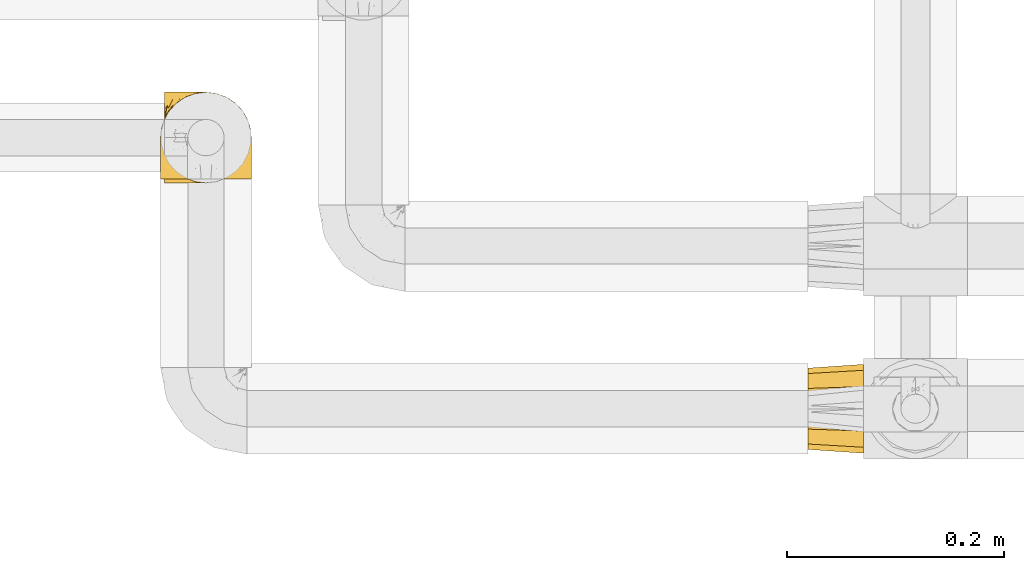
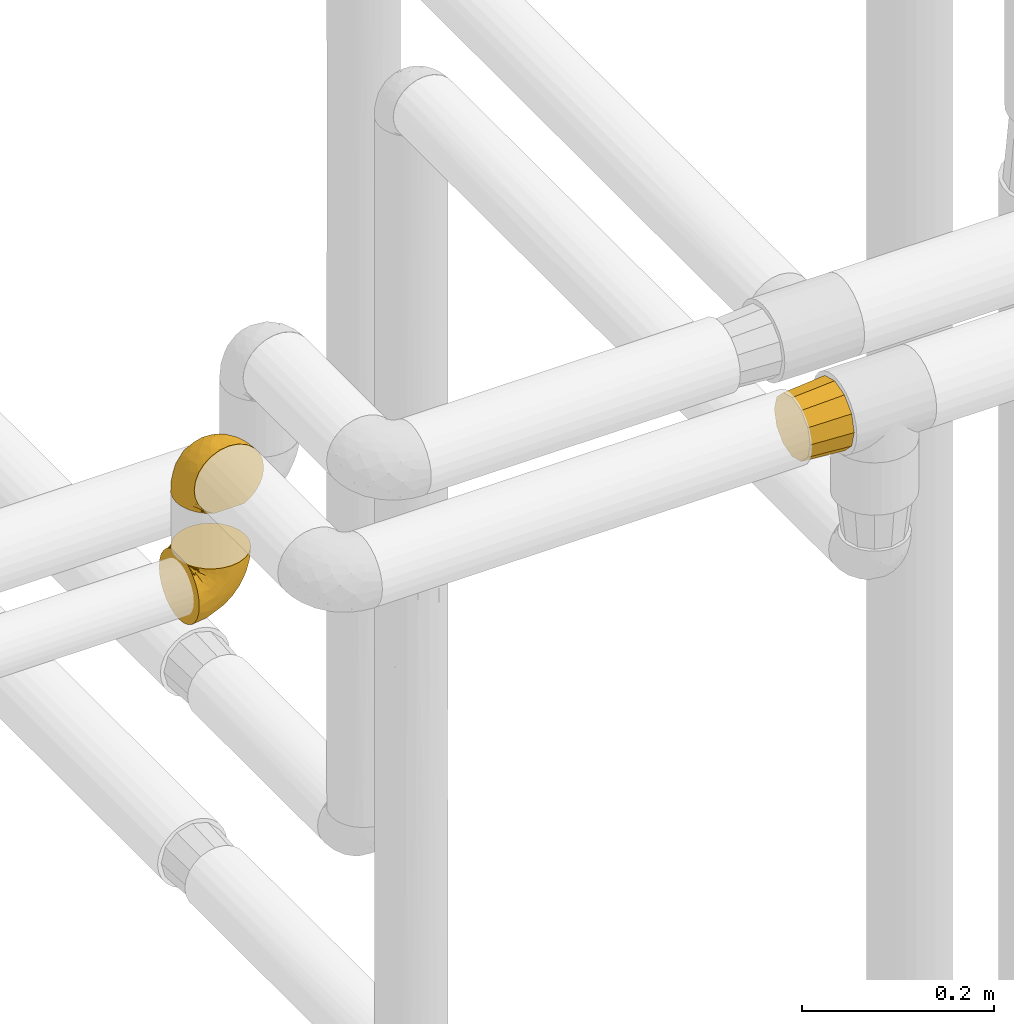
# One storey, part 58 of 827: 3 coverings.
"""IFC2X3 building model written with IfcOpenShell, lengths in millimetres."""

import ifcopenshell
import ifcopenshell.guid

model = None  # the IFC model being written
_history = None  # IfcOwnerHistory: only IFC2X3 demands one
_inside = {}  # id of a spatial element -> (the spatial element, [elements in it])
_under = {}  # id of a project, library or spatial element -> (it, [spatial elements below it])
_declared = {}  # id of a project -> (the project, [libraries it declares])
_typed = {}  # id of a type object -> (the type object, [elements of that type])
_made_of = {}  # id of a material, layer set ... -> (it, [elements and type objects made of it])


def new_model(schema):
    """Start an empty IFC model of exactly this schema.

    Asked for "IFC4X3", IfcOpenShell would pick the latest addendum, in which some entities
    have other attributes; the version numbers below select the first issue.
    IFC2X3 requires an IfcOwnerHistory on every rooted entity: one is made here for all.
    """
    global model, _history
    if schema == "IFC4X3":
        model = ifcopenshell.file(schema_version=(4, 3, 0, 0))
    else:
        model = ifcopenshell.file(schema=schema)
    _inside.clear()
    _under.clear()
    _declared.clear()
    _typed.clear()
    _made_of.clear()
    _history = None
    if model.schema == "IFC2X3":
        org = make("IfcOrganization", Name="unknown")
        user = make(
            "IfcPersonAndOrganization",
            ThePerson=make("IfcPerson", FamilyName="unknown"),
            TheOrganization=org,
        )
        app = make(
            "IfcApplication",
            ApplicationDeveloper=org,
            Version="unknown",
            ApplicationFullName="unknown",
            ApplicationIdentifier="unknown",
        )
        _history = make(
            "IfcOwnerHistory",
            OwningUser=user,
            OwningApplication=app,
            ChangeAction="ADDED",
            CreationDate=0,
        )
    return model


def make(cls, **values):
    """One entity of the class cls with the attributes given. An attribute that is None is left unset."""
    return model.create_entity(
        cls, **{name: value for name, value in values.items() if value is not None}
    )


def entity(cls, *values):
    """Any entity or typed value of the class cls, its attributes in the order of the schema. None: left unset."""
    e = model.create_entity(cls)
    for i, value in enumerate(values):
        if value is not None:
            e[i] = value
    return e


def rooted(cls, **values):
    """An entity with a GlobalId (a new one), such as an element, a storey or a relation."""
    return make(cls, GlobalId=ifcopenshell.guid.new(), OwnerHistory=_history, **values)


def si_unit(unit_type, name, prefix=None):
    """IfcSIUnit, for example si_unit("LENGTHUNIT", "METRE", prefix="MILLI")."""
    return make("IfcSIUnit", UnitType=unit_type, Prefix=prefix, Name=name)


def converted_unit(unit_type, name, factor, base, dimensions=None, offset=None):
    """IfcConversionBasedUnit, such as the inch: factor (a typed value) times the base unit."""
    return make(
        "IfcConversionBasedUnit"
        if offset is None
        else "IfcConversionBasedUnitWithOffset",
        ConversionOffset=offset,
        Dimensions=None
        if dimensions is None
        else entity("IfcDimensionalExponents", *dimensions),
        UnitType=unit_type,
        Name=name,
        ConversionFactor=make(
            "IfcMeasureWithUnit", ValueComponent=factor, UnitComponent=base
        ),
    )


def derived_unit(unit_type, elements):
    """IfcDerivedUnit: a product of units, each with its exponent."""
    return make(
        "IfcDerivedUnit",
        Elements=[
            make("IfcDerivedUnitElement", Unit=unit, Exponent=power)
            for unit, power in elements
        ],
        UnitType=unit_type,
    )


def assignment(units):
    """IfcUnitAssignment: the units of a project."""
    return None if units is None else make("IfcUnitAssignment", Units=units)


def point(xyz):
    """IfcCartesianPoint."""
    return None if xyz is None else make("IfcCartesianPoint", Coordinates=xyz)


def direction(xyz):
    """IfcDirection."""
    return None if xyz is None else make("IfcDirection", DirectionRatios=xyz)


def frame(location, z_axis=None, x_axis=None):
    """IfcAxis2Placement3D, a coordinate frame: its origin and axes. An axis left out is left unset."""
    return make(
        "IfcAxis2Placement3D",
        Location=point(location),
        Axis=direction(z_axis),
        RefDirection=direction(x_axis),
    )


def origin():
    """The frame at (0, 0, 0) with its axes left unset."""
    return frame((0.0, 0.0, 0.0))


def place(relative_to, where):
    """IfcLocalPlacement: puts the frame where relative to a parent placement (None: the world)."""
    return make(
        "IfcLocalPlacement", PlacementRelTo=relative_to, RelativePlacement=where
    )


def context(
    kind, dimensions, precision=None, world=None, true_north=None, identifier=None
):
    """IfcGeometricRepresentationContext, for example the 3D "Model" context."""
    return make(
        "IfcGeometricRepresentationContext",
        ContextIdentifier=identifier,
        ContextType=kind,
        CoordinateSpaceDimension=dimensions,
        Precision=precision,
        WorldCoordinateSystem=world,
        TrueNorth=true_north,
    )


def subcontext(parent, identifier, kind, view, scale=None):
    """IfcGeometricRepresentationSubContext, for example "Body" below "Model"."""
    return make(
        "IfcGeometricRepresentationSubContext",
        ContextIdentifier=identifier,
        ContextType=kind,
        ParentContext=parent,
        TargetScale=scale,
        TargetView=view,
    )


def project(units=None, contexts=None):
    """IfcProject with its units and contexts."""
    return rooted(
        "IfcProject",
        Name="project",
        RepresentationContexts=contexts,
        UnitsInContext=assignment(units),
    )


def spatial(cls, under=None, at=None, **own):
    """A site, building, storey or space (cls), placed at a placement, below another one or the project."""
    s = rooted(cls, ObjectPlacement=at, **own)
    if under is not None:
        _under.setdefault(under.id(), (under, []))[1].append(s)
    return s


def faces_of(points, faces, orient=None, outer=None):
    """IfcFace entities. A face is a list of loops; a loop is a list of indices into points, from 0.

    orient and outer hold one flag for each loop. By default every Orientation is true, the
    first loop of a face is its IfcFaceOuterBound and the others are IfcFaceBound.
    """
    made = []
    for i, loops in enumerate(faces):
        bounds = []
        for j, loop in enumerate(loops):
            is_outer = j == 0 if outer is None else outer[i][j]
            bounds.append(
                make(
                    "IfcFaceOuterBound" if is_outer else "IfcFaceBound",
                    Bound=make("IfcPolyLoop", Polygon=[points[k] for k in loop]),
                    Orientation=True if orient is None else orient[i][j],
                )
            )
        made.append(make("IfcFace", Bounds=bounds))
    return made


def faceted_brep(points, faces, orient=None, outer=None, voids=None):
    """IfcFacetedBrep: a solid bounded by flat faces; with voids (closed shells), ...WithVoids."""
    shared = [point(p) for p in points]
    hull = make("IfcClosedShell", CfsFaces=faces_of(shared, faces, orient, outer))
    if voids is None:
        return make("IfcFacetedBrep", Outer=hull)
    return make(
        "IfcFacetedBrepWithVoids",
        Outer=hull,
        Voids=[
            make(cls, CfsFaces=faces_of(shared, fs, o, b)) for cls, fs, o, b in voids
        ],
    )


def shape(context_of_items, identifier, shape_type, items):
    """IfcShapeRepresentation: the items that make up one representation, for example the "Body"."""
    return make(
        "IfcShapeRepresentation",
        ContextOfItems=context_of_items,
        RepresentationIdentifier=identifier,
        RepresentationType=shape_type,
        Items=items,
    )


def made_of(thing, what):
    """Note that an element or type object is made of a material, layer set ...; save() writes the relation."""
    if what is not None:
        _made_of.setdefault(what.id(), (what, []))[1].append(thing)
    return thing


def element(
    cls,
    number,
    at=None,
    inside=None,
    cuts=None,
    type_object=None,
    material=None,
    context=None,
    identifier="Body",
    shape_type=None,
    held_by="IfcProductDefinitionShape",
    body=None,
    shapes=None,
    **own,
):
    """One element of the class cls, such as IfcWall. Its Tag is "e" and its number.

    at: its placement. inside: the storey or other place that contains it. cuts: it is an
    opening in that element (IfcRelVoidsElement). A single representation is given by context,
    identifier, shape_type and body (its items); several are given by shapes. held_by: the class
    of the entity that holds the representations. save() writes the other relations.
    """
    e = rooted(cls, Tag="e%d" % number, ObjectPlacement=at, **own)
    if body is not None:
        shapes = [shape(context, identifier, shape_type, body)]
    if shapes is not None:
        e.Representation = make(held_by, Representations=shapes)
    if inside is not None:
        _inside.setdefault(inside.id(), (inside, []))[1].append(e)
    if cuts is not None:
        rooted(
            "IfcRelVoidsElement", RelatingBuildingElement=cuts, RelatedOpeningElement=e
        )
    if type_object is not None:
        _typed.setdefault(type_object.id(), (type_object, []))[1].append(e)
    return made_of(e, material)


def aggregate(whole, parts):
    """IfcRelAggregates: a whole, such as a stair, and the parts it consists of."""
    return rooted("IfcRelAggregates", RelatingObject=whole, RelatedObjects=parts)


def save(model, path):
    """Write the relations noted so far, then the file.

    IfcRelAggregates (storeys below a building ...), IfcRelContainedInSpatialStructure (elements
    in a storey), IfcRelDefinesByType, IfcRelAssociatesMaterial and IfcRelDeclares: one each for
    every whole, place, type object, material and project.
    """
    for whole, parts in _under.values():
        aggregate(whole, parts)
    for where, things in _inside.values():
        rooted(
            "IfcRelContainedInSpatialStructure",
            RelatedElements=things,
            RelatingStructure=where,
        )
    for kind, things in _typed.values():
        rooted("IfcRelDefinesByType", RelatedObjects=things, RelatingType=kind)
    for what, things in _made_of.values():
        rooted("IfcRelAssociatesMaterial", RelatedObjects=things, RelatingMaterial=what)
    for by, libraries in _declared.values():
        rooted("IfcRelDeclares", RelatingContext=by, RelatedDefinitions=libraries)
    model.write(path)


model = new_model("IFC2X3")

# Units and contexts
model_context = context("Model", 3, precision=0.01, world=origin(), true_north=direction((6.12303176911189e-17, 1.0)))
body_context = subcontext(model_context, "Body", "Model", "MODEL_VIEW")
ifc_project = project(units=[si_unit("LENGTHUNIT", "METRE", prefix="MILLI"), si_unit("AREAUNIT", "SQUARE_METRE"), si_unit("VOLUMEUNIT", "CUBIC_METRE"), converted_unit("PLANEANGLEUNIT", "DEGREE", entity("IfcRatioMeasure", 0.0174532925199433), si_unit("PLANEANGLEUNIT", "RADIAN"), dimensions=[0, 0, 0, 0, 0, 0, 0]), si_unit("MASSUNIT", "GRAM", prefix="KILO"), derived_unit("MASSDENSITYUNIT", [(si_unit("MASSUNIT", "GRAM", prefix="KILO"), 1), (si_unit("LENGTHUNIT", "METRE"), -3)]), derived_unit("MOMENTOFINERTIAUNIT", [(si_unit("LENGTHUNIT", "METRE"), 4)]), si_unit("TIMEUNIT", "SECOND"), si_unit("FREQUENCYUNIT", "HERTZ"), si_unit("THERMODYNAMICTEMPERATUREUNIT", "DEGREE_CELSIUS"), derived_unit("THERMALTRANSMITTANCEUNIT", [(si_unit("MASSUNIT", "GRAM", prefix="KILO"), 1), (si_unit("THERMODYNAMICTEMPERATUREUNIT", "KELVIN"), -1), (si_unit("TIMEUNIT", "SECOND"), -3)]), derived_unit("VOLUMETRICFLOWRATEUNIT", [(si_unit("LENGTHUNIT", "METRE"), 3), (si_unit("TIMEUNIT", "SECOND"), -1)]), derived_unit("MASSFLOWRATEUNIT", [(si_unit("MASSUNIT", "GRAM", prefix="KILO"), 1), (si_unit("TIMEUNIT", "SECOND"), -1)]), derived_unit("ROTATIONALFREQUENCYUNIT", [(si_unit("TIMEUNIT", "SECOND"), -1)]), si_unit("ELECTRICCURRENTUNIT", "AMPERE"), si_unit("ELECTRICVOLTAGEUNIT", "VOLT"), si_unit("POWERUNIT", "WATT"), si_unit("FORCEUNIT", "NEWTON", prefix="KILO"), si_unit("ILLUMINANCEUNIT", "LUX"), si_unit("LUMINOUSFLUXUNIT", "LUMEN"), si_unit("LUMINOUSINTENSITYUNIT", "CANDELA"), derived_unit("USERDEFINED", [(si_unit("MASSUNIT", "GRAM", prefix="KILO"), -1), (si_unit("LENGTHUNIT", "METRE"), -2), (si_unit("TIMEUNIT", "SECOND"), 3), (si_unit("LUMINOUSFLUXUNIT", "LUMEN"), 1)]), derived_unit("LINEARVELOCITYUNIT", [(si_unit("LENGTHUNIT", "METRE"), 1), (si_unit("TIMEUNIT", "SECOND"), -1)]), si_unit("PRESSUREUNIT", "PASCAL"), derived_unit("USERDEFINED", [(si_unit("LENGTHUNIT", "METRE"), -2), (si_unit("MASSUNIT", "GRAM", prefix="KILO"), 1), (si_unit("TIMEUNIT", "SECOND"), -2)]), derived_unit("LINEARFORCEUNIT", [(si_unit("MASSUNIT", "GRAM", prefix="KILO"), 1), (si_unit("LENGTHUNIT", "METRE"), 1), (si_unit("TIMEUNIT", "SECOND"), -2), (si_unit("LENGTHUNIT", "METRE"), -1)]), derived_unit("PLANARFORCEUNIT", [(si_unit("MASSUNIT", "GRAM", prefix="KILO"), 1), (si_unit("LENGTHUNIT", "METRE"), 1), (si_unit("TIMEUNIT", "SECOND"), -2), (si_unit("LENGTHUNIT", "METRE"), -2)])], contexts=[model_context])

# Site, building, storey
site_placement = place(None, origin())
site = spatial("IfcSite", under=ifc_project, at=site_placement, CompositionType="ELEMENT")
building_placement = place(site_placement, origin())
building = spatial("IfcBuilding", under=site, at=building_placement, CompositionType="ELEMENT")
storey_placement = place(building_placement, frame((0.0, 0.0, 28200.0)))
storey = spatial("IfcBuildingStorey", under=building, at=storey_placement, Name="08", CompositionType="ELEMENT", Elevation=28200.0)

# Coverings
covering_1_placement = place(storey_placement, frame((19078.69, 9553.2, 2956.87)))
element("IfcCovering", 1, at=covering_1_placement, inside=storey, Name=":ADSK_", ObjectType=":ADSK_", PredefinedType="INSULATION", context=body_context, shape_type="Brep", body=[
    faceted_brep([(5.74, 57.76, 1.6), (10.73, 65.69, 1.6), (17.36, 72.32, 1.6), (25.29, 77.3, 1.6), (34.14, 80.4, 1.6), (43.45, 81.45, 1.6), (52.76, 80.39, 1.6), (61.61, 77.3, 1.6), (69.54, 72.31, 1.6), (76.17, 65.68, 1.6), (81.15, 57.75, 1.6), (84.25, 48.9, 1.6), (85.3, 39.6, 1.6), (84.23, 30.22, 1.6), (81.1, 21.33, 1.6), (76.06, 13.37, 1.6), (69.36, 6.73, 1.6), (61.36, 1.77, 1.6), (60.44, 1.77, 1.6), (59.52, 1.77, 1.6), (58.72, 1.77, 1.6), (57.4, 1.77, 1.6), (56.08, 1.77, 1.6), (54.76, 1.77, 1.6), (53.44, 1.77, 1.6), (52.12, 1.77, 1.6), (50.8, 1.77, 1.6), (49.47, 1.77, 1.6), (48.15, 1.77, 1.6), (46.83, 1.77, 1.6), (45.51, 1.77, 1.6), (44.19, 1.77, 1.6), (42.87, 1.77, 1.6), (41.55, 1.77, 1.6), (40.23, 1.77, 1.6), (39.31, 1.77, 1.6), (38.39, 1.77, 1.6), (37.48, 1.77, 1.6), (36.56, 1.77, 1.6), (35.64, 1.77, 1.6), (34.72, 1.77, 1.6), (33.8, 1.77, 1.6), (32.88, 1.77, 1.6), (31.96, 1.77, 1.6), (31.05, 1.77, 1.6), (30.13, 1.77, 1.6), (29.21, 1.77, 1.6), (28.29, 1.77, 1.6), (27.37, 1.77, 1.6), (26.45, 1.77, 1.6), (25.53, 1.77, 1.6), (17.52, 6.74, 1.6), (10.82, 13.38, 1.6), (5.78, 21.35, 1.6), (2.65, 30.24, 1.6), (1.6, 39.6, 1.6), (2.65, 48.91, 1.6), (69.37, 1.6, 6.74), (76.06, 1.6, 13.37), (81.1, 1.6, 21.34), (84.23, 1.6, 30.23), (85.3, 1.6, 39.6), (83.87, 1.6, 50.43), (79.69, 1.6, 60.52), (73.04, 1.6, 69.19), (64.37, 1.6, 75.84), (54.28, 1.6, 80.02), (43.45, 1.6, 81.45), (32.61, 1.6, 80.02), (22.52, 1.6, 75.84), (13.85, 1.6, 69.19), (7.2, 1.6, 60.52), (3.02, 1.6, 50.43), (1.6, 1.6, 39.6), (2.66, 1.6, 30.23), (5.79, 1.6, 21.34), (10.83, 1.6, 13.37), (17.52, 1.6, 6.74), (25.53, 1.6, 1.77), (26.45, 1.6, 1.77), (27.77, 1.6, 1.77), (28.89, 1.6, 1.77), (30.01, 1.6, 1.77), (31.13, 1.6, 1.77), (32.25, 1.6, 1.77), (33.37, 1.6, 1.77), (34.49, 1.6, 1.77), (35.61, 1.6, 1.77), (36.73, 1.6, 1.77), (37.85, 1.6, 1.77), (38.97, 1.6, 1.77), (40.09, 1.6, 1.77), (41.21, 1.6, 1.77), (42.33, 1.6, 1.77), (43.45, 1.6, 1.77), (44.77, 1.6, 1.77), (46.09, 1.6, 1.77), (47.41, 1.6, 1.77), (48.73, 1.6, 1.77), (50.05, 1.6, 1.77), (51.37, 1.6, 1.77), (52.69, 1.6, 1.77), (54.01, 1.6, 1.77), (54.93, 1.6, 1.77), (55.85, 1.6, 1.77), (56.76, 1.6, 1.77), (57.68, 1.6, 1.77), (58.6, 1.6, 1.77), (59.52, 1.6, 1.77), (60.44, 1.6, 1.77), (61.36, 1.6, 1.77), (32.81, 1.71, 1.73), (31.73, 1.73, 1.72), (50.71, 1.71, 1.73), (51.76, 1.72, 1.72), (42.89, 1.71, 1.73), (41.81, 1.72, 1.73), (25.53, 1.72, 1.72), (26.91, 1.72, 1.72), (40.71, 1.72, 1.72), (60.15, 1.72, 1.72), (39.53, 1.72, 1.72), (57.22, 1.72, 1.73), (58.17, 1.7, 1.74), (47.12, 1.72, 1.72), (33.93, 1.73, 1.71), (35.05, 1.72, 1.73), (46.09, 1.73, 1.71), (45.02, 1.73, 1.72), (43.95, 1.72, 1.73), (59.12, 1.72, 1.72), (38.49, 1.71, 1.73), (49.68, 1.72, 1.72), (53.35, 1.71, 1.73), (54.4, 1.72, 1.72), (56.2, 1.72, 1.72), (36.2, 1.72, 1.72), (37.29, 1.73, 1.71), (30.57, 1.72, 1.72), (29.45, 1.71, 1.73), (28.01, 1.73, 1.71), (61.36, 1.72, 1.72), (25.53, 1.74, 1.68), (25.53, 1.75, 1.64), (61.36, 1.75, 1.64), (61.36, 1.74, 1.68), (25.53, 1.64, 1.75), (25.53, 1.68, 1.74), (61.36, 1.68, 1.74), (61.36, 1.64, 1.75), (55.3, 1.74, 1.7), (48.18, 1.71, 1.73), (82.92, 8.98, 24.54), (85.3, 37.05, 11.1), (82.92, 24.69, 8.47), (78.8, 15.28, 9.11), (78.8, 16.86, 4.86), (70.46, 6.58, 5.0), (71.16, 5.71, 6.81), (85.3, 11.1, 37.05), (76.1, 10.79, 9.03), (72.9, 4.13, 9.47), (78.81, 6.62, 16.39), (72.89, 9.52, 3.95), (74.06, 6.14, 9.9), (83.71, 17.79, 22.7), (85.3, 20.6, 34.5), (85.3, 8.73, 37.68), (83.61, 23.66, 15.82), (85.3, 34.5, 20.6), (80.61, 15.32, 14.37), (85.3, 27.55, 27.55), (67.83, 3.31, 5.2), (78.81, 9.81, 14.88), (85.3, 37.68, 8.73), (54.78, 67.23, 44.27), (57.27, 76.64, 20.94), (43.45, 75.37, 32.15), (84.45, 14.58, 46.13), (84.39, 23.71, 42.67), (77.16, 34.34, 55.18), (68.92, 29.1, 67.27), (76.65, 18.02, 62.91), (82.11, 22.27, 51.5), (82.11, 10.97, 54.79), (78.88, 56.79, 25.78), (78.88, 60.76, 13.05), (73.04, 67.04, 18.46), (84.47, 36.11, 32.4), (65.72, 68.85, 31.07), (51.16, 24.58, 77.32), (59.46, 21.54, 75.62), (43.45, 78.4, 16.9), (68.92, 14.11, 71.69), (51.18, 53.42, 61.4), (57.42, 58.19, 54.47), (83.48, 44.49, 27.66), (82.95, 51.77, 14.53), (65.72, 73.69, 15.56), (78.97, 45.89, 42.26), (82.64, 35.97, 41.51), (75.14, 56.55, 36.93), (68.58, 60.03, 42.72), (61.95, 63.64, 44.68), (58.11, 34.98, 71.2), (51.07, 40.58, 70.48), (43.45, 32.15, 75.37), (58.51, 47.26, 63.65), (43.45, 58.06, 58.06), (43.45, 66.71, 45.11), (43.45, 16.9, 78.4), (65.68, 52.08, 54.95), (70.41, 41.21, 59.31), (73.04, 49.76, 49.01), (43.45, 45.11, 66.71), (4.78, 15.65, 53.75), (35.48, 24.57, 77.27), (29.45, 50.54, 61.6), (32.11, 67.25, 44.24), (13.86, 67.06, 18.46), (21.19, 73.7, 15.55), (10.24, 26.13, 60.14), (17.97, 19.54, 70.5), (18.88, 38.96, 63.0), (8.01, 56.8, 25.78), (8.01, 60.77, 13.05), (3.95, 51.78, 14.53), (22.45, 59.09, 48.5), (2.4, 19.25, 44.23), (1.6, 20.6, 34.5), (1.6, 11.1, 37.05), (1.6, 37.68, 8.73), (29.05, 15.21, 77.68), (10.24, 12.76, 64.08), (35.7, 40.93, 70.25), (29.63, 76.65, 20.93), (8.75, 39.5, 49.9), (4.54, 25.01, 49.6), (21.19, 68.86, 31.06), (2.28, 26.7, 39.62), (2.53, 34.95, 34.42), (1.6, 34.5, 20.6), (1.6, 27.55, 27.55), (13.86, 61.27, 33.36), (3.41, 44.5, 27.68), (1.6, 37.05, 11.1), (2.35, 10.25, 46.67), (13.86, 49.78, 49.0), (7.35, 47.51, 38.94), (27.43, 29.38, 73.05), (13.39, 40.01, 56.63), (4.32, 33.36, 43.85), (3.97, 8.98, 24.54), (3.27, 23.67, 15.82), (3.97, 24.71, 8.47), (8.08, 15.29, 9.12), (13.99, 4.13, 9.47), (12.83, 6.14, 9.91), (8.08, 4.96, 16.85), (8.08, 9.81, 14.88), (19.06, 3.31, 5.2), (15.74, 5.7, 6.81), (13.98, 9.53, 3.96), (16.42, 6.59, 5.0), (8.08, 16.63, 5.86), (6.27, 15.34, 14.38), (10.78, 10.8, 9.04), (3.18, 17.79, 22.7)], [[[0, 1, 2, 3, 4, 5, 6, 7, 8, 9, 10, 11, 12, 13, 14, 15, 16, 17, 18, 19, 20, 21, 22, 23, 24, 25, 26, 27, 28, 29, 30, 31, 32, 33, 34, 35, 36, 37, 38, 39, 40, 41, 42, 43, 44, 45, 46, 47, 48, 49, 50, 51, 52, 53, 54, 55, 56]], [[57, 58, 59, 60, 61, 62, 63, 64, 65, 66, 67, 68, 69, 70, 71, 72, 73, 74, 75, 76, 77, 78, 79, 80, 81, 82, 83, 84, 85, 86, 87, 88, 89, 90, 91, 92, 93, 94, 95, 96, 97, 98, 99, 100, 101, 102, 103, 104, 105, 106, 107, 108, 109, 110]], [[111, 84, 112]], [[113, 26, 114]], [[114, 101, 100]], [[115, 93, 116]], [[79, 117, 118]], [[33, 116, 119]], [[117, 49, 118]], [[19, 18, 120]], [[119, 121, 34]], [[122, 21, 123]], [[97, 96, 124]], [[86, 125, 126]], [[116, 92, 119]], [[127, 96, 128]], [[32, 129, 115]], [[19, 120, 130]], [[121, 90, 131]], [[94, 115, 129]], [[115, 116, 32]], [[118, 49, 48]], [[113, 99, 132]], [[133, 114, 25]], [[24, 134, 133]], [[135, 22, 122]], [[136, 137, 88]], [[84, 83, 112]], [[138, 82, 139]], [[130, 20, 19]], [[118, 48, 140]], [[81, 140, 139]], [[123, 21, 20]], [[141, 120, 18]], [[139, 82, 81]], [[130, 107, 123]], [[49, 117, 142, 143, 50]], [[18, 17, 144, 145, 141]], [[79, 78, 146, 147, 117]], [[109, 141, 148, 149, 110]], [[102, 133, 134]], [[105, 135, 122]], [[118, 80, 79]], [[80, 118, 140]], [[120, 109, 108]], [[47, 46, 140, 48]], [[81, 80, 140]], [[44, 112, 138]], [[93, 115, 94]], [[46, 139, 140]], [[46, 45, 139]], [[139, 45, 138]], [[138, 112, 83]], [[85, 84, 111]], [[112, 43, 111]], [[83, 82, 138]], [[106, 122, 123]], [[105, 122, 106]], [[21, 122, 22]], [[124, 29, 28]], [[33, 32, 116]], [[128, 129, 31]], [[32, 31, 129]], [[34, 33, 119]], [[116, 93, 92]], [[129, 95, 94]], [[95, 129, 128]], [[41, 40, 125, 42]], [[119, 91, 121]], [[36, 35, 131, 37]], [[137, 131, 89]], [[121, 131, 35]], [[90, 121, 91]], [[119, 92, 91]], [[136, 126, 39]], [[125, 86, 85]], [[42, 125, 111]], [[85, 111, 125]], [[150, 23, 22]], [[130, 108, 107]], [[130, 123, 20]], [[107, 106, 123]], [[137, 37, 131]], [[136, 38, 137]], [[89, 88, 137]], [[131, 90, 89]], [[124, 151, 97]], [[40, 39, 126]], [[87, 126, 136]], [[86, 126, 87]], [[136, 88, 87]], [[40, 126, 125]], [[39, 38, 136]], [[95, 128, 96]], [[30, 128, 31]], [[29, 124, 127]], [[127, 128, 30]], [[151, 124, 28]], [[127, 30, 29]], [[127, 124, 96]], [[151, 98, 97]], [[45, 44, 138]], [[26, 113, 132]], [[113, 100, 99]], [[132, 151, 27]], [[27, 26, 132]], [[26, 25, 114]], [[100, 113, 114]], [[101, 133, 102]], [[133, 101, 114]], [[28, 27, 151]], [[132, 99, 98]], [[23, 134, 24]], [[25, 24, 133]], [[134, 23, 150]], [[135, 104, 150]], [[150, 104, 103]], [[103, 102, 134]], [[130, 120, 108]], [[109, 120, 141]], [[42, 111, 43]], [[112, 44, 43]], [[104, 135, 105]], [[134, 150, 103]], [[135, 150, 22]], [[35, 34, 121]], [[137, 38, 37]], [[98, 151, 132]], [[59, 152, 60]], [[13, 153, 154]], [[155, 156, 154]], [[157, 158, 141]], [[159, 60, 152]], [[160, 157, 155]], [[161, 162, 58]], [[58, 162, 59]], [[144, 16, 163]], [[58, 57, 161]], [[162, 161, 164]], [[157, 163, 155]], [[163, 16, 15]], [[57, 149, 161]], [[152, 165, 166]], [[157, 144, 163]], [[60, 159, 167, 61]], [[156, 14, 154]], [[163, 156, 155]], [[155, 154, 168]], [[168, 154, 169]], [[155, 170, 160]], [[57, 110, 149]], [[144, 17, 16]], [[156, 15, 14]], [[171, 165, 168]], [[158, 164, 172]], [[14, 13, 154]], [[157, 141, 145, 144]], [[173, 164, 158]], [[173, 160, 170]], [[171, 166, 165]], [[168, 165, 170]], [[168, 169, 171]], [[152, 173, 165]], [[170, 155, 168]], [[165, 173, 170]], [[160, 173, 158]], [[172, 149, 148]], [[148, 141, 158]], [[158, 157, 160]], [[152, 166, 159]], [[173, 152, 162]], [[59, 162, 152]], [[13, 12, 174, 153]], [[153, 169, 154]], [[15, 156, 163]], [[162, 164, 173]], [[172, 164, 161]], [[149, 172, 161]], [[158, 172, 148]], [[175, 176, 177]], [[178, 166, 179]], [[180, 181, 182]], [[183, 184, 178]], [[185, 186, 187]], [[171, 188, 179]], [[174, 12, 11]], [[189, 176, 175]], [[190, 66, 191]], [[176, 6, 192]], [[193, 65, 64]], [[63, 184, 182]], [[63, 182, 64]], [[65, 193, 191]], [[184, 63, 62]], [[175, 194, 195]], [[196, 169, 197]], [[174, 11, 197]], [[8, 7, 198]], [[187, 9, 8]], [[197, 169, 153, 174]], [[197, 11, 10]], [[186, 197, 10]], [[199, 180, 200]], [[197, 185, 196]], [[201, 189, 202]], [[201, 187, 189]], [[195, 203, 175]], [[191, 204, 190]], [[176, 7, 6]], [[177, 176, 192]], [[189, 198, 176]], [[65, 191, 66]], [[198, 187, 8]], [[205, 206, 190]], [[9, 186, 10]], [[181, 207, 204]], [[208, 175, 177, 209]], [[66, 190, 210]], [[211, 212, 213]], [[190, 204, 205]], [[180, 182, 183]], [[193, 182, 181]], [[62, 61, 167]], [[196, 185, 199]], [[196, 200, 188]], [[6, 5, 192]], [[176, 198, 7]], [[187, 198, 189]], [[187, 186, 9]], [[197, 186, 185]], [[200, 180, 183]], [[180, 213, 212]], [[179, 183, 178]], [[185, 201, 199]], [[210, 190, 206]], [[210, 67, 66]], [[205, 204, 207]], [[194, 205, 207]], [[194, 214, 205]], [[195, 194, 207]], [[208, 194, 175]], [[207, 211, 195]], [[202, 203, 211]], [[212, 207, 181]], [[202, 211, 213]], [[201, 202, 213]], [[189, 175, 203]], [[199, 201, 213]], [[187, 201, 185]], [[180, 199, 213]], [[196, 199, 200]], [[211, 203, 195]], [[189, 203, 202]], [[207, 212, 211]], [[180, 212, 181]], [[214, 194, 208]], [[214, 206, 205]], [[196, 188, 169]], [[181, 204, 191]], [[182, 193, 64]], [[191, 193, 181]], [[178, 62, 167]], [[182, 184, 183]], [[62, 178, 184]], [[178, 167, 159, 166]], [[171, 179, 166]], [[200, 183, 179]], [[179, 188, 200]], [[169, 188, 171]], [[71, 215, 72]], [[206, 216, 210]], [[217, 208, 218]], [[216, 68, 210]], [[219, 220, 2]], [[221, 222, 223]], [[224, 225, 226]], [[227, 223, 217]], [[228, 229, 230]], [[56, 231, 226]], [[232, 222, 69]], [[56, 55, 231]], [[70, 233, 71]], [[71, 233, 215]], [[0, 56, 226]], [[208, 217, 234]], [[218, 177, 235]], [[221, 236, 237]], [[238, 220, 219]], [[1, 219, 2]], [[68, 216, 232]], [[235, 3, 220]], [[235, 192, 4]], [[1, 0, 225]], [[228, 239, 229]], [[240, 241, 242]], [[243, 238, 219]], [[224, 226, 244]], [[226, 241, 244]], [[3, 235, 4]], [[69, 222, 70]], [[225, 219, 1]], [[218, 235, 238]], [[243, 219, 224]], [[218, 227, 217]], [[3, 2, 220]], [[218, 208, 209, 177]], [[226, 231, 245, 241]], [[215, 228, 246]], [[247, 248, 236]], [[248, 224, 244]], [[223, 222, 249]], [[233, 222, 221]], [[242, 239, 240]], [[248, 247, 243]], [[217, 223, 249]], [[250, 247, 236]], [[216, 234, 249]], [[218, 238, 227]], [[192, 235, 177]], [[192, 5, 4]], [[72, 246, 73]], [[235, 220, 238]], [[226, 225, 0]], [[219, 225, 224]], [[240, 248, 244]], [[239, 242, 229]], [[236, 248, 251]], [[68, 67, 210]], [[234, 216, 206]], [[216, 249, 232]], [[234, 206, 214, 208]], [[249, 234, 217]], [[222, 232, 249]], [[69, 68, 232]], [[246, 228, 230]], [[237, 228, 215]], [[243, 227, 238]], [[223, 227, 247]], [[73, 246, 230]], [[215, 246, 72]], [[248, 243, 224]], [[227, 243, 247]], [[237, 236, 251]], [[250, 221, 223]], [[222, 233, 70]], [[215, 233, 221]], [[221, 237, 215]], [[239, 237, 251]], [[237, 239, 228]], [[239, 251, 240]], [[248, 240, 251]], [[241, 240, 244]], [[221, 250, 236]], [[223, 247, 250]], [[74, 230, 252]], [[253, 254, 255]], [[146, 77, 256]], [[257, 258, 259]], [[260, 256, 257]], [[260, 261, 147]], [[75, 74, 252]], [[51, 143, 262]], [[263, 143, 142, 117]], [[256, 77, 76]], [[252, 258, 75]], [[253, 241, 254]], [[254, 245, 54]], [[258, 256, 76]], [[53, 52, 264]], [[255, 265, 253]], [[254, 264, 255]], [[255, 264, 262]], [[75, 258, 76]], [[265, 255, 266]], [[255, 262, 263]], [[51, 50, 143]], [[54, 245, 231, 55]], [[51, 262, 52]], [[253, 267, 242]], [[254, 54, 53]], [[266, 259, 265]], [[146, 78, 77]], [[263, 117, 261]], [[146, 256, 260]], [[257, 259, 261]], [[267, 253, 265]], [[229, 267, 252]], [[242, 267, 229]], [[242, 241, 253]], [[252, 267, 259]], [[255, 263, 266]], [[259, 267, 265]], [[261, 117, 147]], [[263, 261, 266]], [[259, 266, 261]], [[230, 74, 73]], [[230, 229, 252]], [[259, 258, 252]], [[254, 241, 245]], [[53, 264, 254]], [[52, 262, 264]], [[143, 263, 262]], [[258, 257, 256]], [[261, 260, 257]], [[146, 260, 147]]]),
])
covering_2_placement = place(storey_placement, frame((19082.54, 9549.35, 2806.55)))
element("IfcCovering", 2, at=covering_2_placement, inside=storey, Name=":ADSK_", ObjectType=":ADSK_", PredefinedType="INSULATION", context=body_context, shape_type="Brep", body=[
    faceted_brep([(1.6, 81.15, 25.28), (1.6, 76.16, 17.35), (1.6, 69.53, 10.72), (1.6, 61.6, 5.74), (1.6, 52.75, 2.64), (1.6, 43.45, 1.6), (1.6, 34.13, 2.65), (1.6, 25.28, 5.74), (1.6, 17.35, 10.73), (1.6, 10.72, 17.36), (1.6, 5.74, 25.29), (1.6, 2.64, 34.14), (1.6, 1.6, 43.45), (1.6, 2.66, 52.82), (1.6, 5.79, 61.71), (1.6, 10.83, 69.67), (1.6, 17.53, 76.31), (1.6, 25.53, 81.27), (1.6, 26.45, 81.27), (1.6, 27.37, 81.27), (1.6, 28.17, 81.27), (1.6, 29.49, 81.27), (1.6, 30.81, 81.27), (1.6, 32.13, 81.27), (1.6, 33.45, 81.27), (1.6, 34.78, 81.27), (1.6, 36.1, 81.27), (1.6, 37.42, 81.27), (1.6, 38.74, 81.27), (1.6, 40.06, 81.27), (1.6, 41.38, 81.27), (1.6, 42.7, 81.27), (1.6, 44.02, 81.27), (1.6, 45.34, 81.27), (1.6, 46.66, 81.27), (1.6, 47.58, 81.27), (1.6, 48.5, 81.27), (1.6, 49.41, 81.27), (1.6, 50.33, 81.27), (1.6, 51.25, 81.27), (1.6, 52.17, 81.27), (1.6, 53.09, 81.27), (1.6, 54.01, 81.27), (1.6, 54.93, 81.27), (1.6, 55.85, 81.27), (1.6, 56.76, 81.27), (1.6, 57.68, 81.27), (1.6, 58.6, 81.27), (1.6, 59.52, 81.27), (1.6, 60.44, 81.27), (1.6, 61.36, 81.27), (1.6, 69.37, 76.3), (1.6, 76.07, 69.66), (1.6, 81.11, 61.69), (1.6, 84.24, 52.8), (1.6, 85.3, 43.45), (1.6, 84.24, 34.13), (6.74, 17.52, 81.45), (13.37, 10.83, 81.45), (21.34, 5.79, 81.45), (30.23, 2.66, 81.45), (39.6, 1.6, 81.45), (50.43, 3.02, 81.45), (60.52, 7.2, 81.45), (69.19, 13.85, 81.45), (75.84, 22.52, 81.45), (80.02, 32.61, 81.45), (81.45, 43.45, 81.45), (80.02, 54.28, 81.45), (75.84, 64.37, 81.45), (69.19, 73.04, 81.45), (60.52, 79.69, 81.45), (50.43, 83.87, 81.45), (39.6, 85.3, 81.45), (30.23, 84.23, 81.45), (21.34, 81.1, 81.45), (13.37, 76.06, 81.45), (6.74, 69.37, 81.45), (1.77, 61.36, 81.45), (1.77, 60.44, 81.45), (1.77, 59.12, 81.45), (1.77, 58.0, 81.45), (1.77, 56.88, 81.45), (1.77, 55.76, 81.45), (1.77, 54.64, 81.45), (1.77, 53.52, 81.45), (1.77, 52.4, 81.45), (1.77, 51.28, 81.45), (1.77, 50.16, 81.45), (1.77, 49.04, 81.45), (1.77, 47.92, 81.45), (1.77, 46.8, 81.45), (1.77, 45.68, 81.45), (1.77, 44.56, 81.45), (1.77, 43.45, 81.45), (1.77, 42.12, 81.45), (1.77, 40.8, 81.45), (1.77, 39.48, 81.45), (1.77, 38.16, 81.45), (1.77, 36.84, 81.45), (1.77, 35.52, 81.45), (1.77, 34.2, 81.45), (1.77, 32.88, 81.45), (1.77, 31.96, 81.45), (1.77, 31.05, 81.45), (1.77, 30.13, 81.45), (1.77, 29.21, 81.45), (1.77, 28.29, 81.45), (1.77, 27.37, 81.45), (1.77, 26.45, 81.45), (1.77, 25.53, 81.45), (1.73, 54.08, 81.33), (1.72, 55.16, 81.32), (1.73, 36.18, 81.33), (1.72, 35.13, 81.32), (1.73, 44.01, 81.33), (1.73, 45.08, 81.32), (1.72, 61.36, 81.32), (1.72, 59.98, 81.32), (1.72, 46.18, 81.32), (1.72, 26.74, 81.32), (1.72, 47.36, 81.32), (1.73, 29.67, 81.32), (1.74, 28.72, 81.34), (1.72, 39.77, 81.32), (1.71, 52.96, 81.31), (1.73, 51.84, 81.33), (1.71, 40.8, 81.31), (1.72, 41.87, 81.32), (1.73, 42.94, 81.33), (1.72, 27.77, 81.32), (1.73, 48.4, 81.33), (1.72, 37.21, 81.32), (1.73, 33.54, 81.33), (1.72, 32.49, 81.32), (1.72, 30.69, 81.32), (1.72, 50.69, 81.32), (1.71, 49.6, 81.31), (1.72, 56.32, 81.32), (1.73, 57.44, 81.33), (1.71, 58.88, 81.31), (1.72, 25.53, 81.32), (1.68, 61.36, 81.3), (1.64, 61.36, 81.29), (1.64, 25.53, 81.29), (1.68, 25.53, 81.3), (1.75, 61.36, 81.4), (1.74, 61.36, 81.36), (1.74, 25.53, 81.36), (1.75, 25.53, 81.4), (1.7, 31.59, 81.3), (1.73, 38.71, 81.33), (24.54, 3.97, 74.06), (11.1, 1.6, 45.99), (8.47, 3.97, 58.35), (9.11, 8.09, 67.76), (4.86, 8.09, 66.18), (5.0, 16.43, 76.46), (6.81, 15.73, 77.33), (37.05, 1.6, 71.95), (9.03, 10.79, 72.25), (9.47, 13.99, 78.91), (16.39, 8.08, 76.42), (3.95, 14.0, 73.52), (9.9, 12.83, 76.9), (22.7, 3.18, 65.25), (34.5, 1.6, 62.45), (37.68, 1.6, 74.31), (15.82, 3.28, 59.38), (20.6, 1.6, 48.54), (14.37, 6.28, 67.72), (27.55, 1.6, 55.49), (5.2, 19.06, 79.73), (14.88, 8.08, 73.23), (8.73, 1.6, 45.36), (44.27, 32.11, 15.81), (20.94, 29.62, 6.4), (32.15, 43.45, 7.67), (46.13, 2.45, 68.46), (42.67, 2.5, 59.33), (55.18, 9.73, 48.7), (67.27, 17.97, 53.94), (62.91, 10.24, 65.02), (51.5, 4.78, 60.77), (54.79, 4.78, 72.07), (25.78, 8.01, 26.25), (13.05, 8.01, 22.29), (18.46, 13.85, 16.0), (32.4, 2.42, 46.93), (31.07, 21.17, 14.19), (77.32, 35.73, 58.46), (75.62, 27.43, 61.51), (16.9, 43.45, 4.64), (71.69, 17.97, 68.93), (61.4, 35.71, 29.62), (54.47, 29.47, 24.85), (27.66, 3.41, 38.55), (14.53, 3.94, 31.27), (15.56, 21.17, 9.35), (42.26, 7.92, 37.15), (41.51, 4.25, 47.07), (36.93, 11.75, 26.49), (42.72, 18.31, 23.01), (44.68, 24.94, 19.4), (71.2, 28.78, 48.06), (70.48, 35.82, 42.46), (75.37, 43.45, 50.89), (63.65, 28.38, 35.78), (58.06, 43.45, 24.98), (45.11, 43.45, 16.33), (78.4, 43.45, 66.14), (54.95, 21.21, 30.96), (59.31, 16.48, 41.83), (49.01, 13.85, 33.28), (66.71, 43.45, 37.94), (53.75, 82.11, 67.39), (77.27, 51.41, 58.47), (61.6, 57.45, 32.5), (44.24, 54.78, 15.79), (18.46, 73.03, 15.99), (15.55, 65.7, 9.34), (60.14, 76.65, 56.91), (70.5, 68.92, 63.5), (63.0, 68.01, 44.08), (25.78, 78.88, 26.24), (13.05, 78.88, 22.27), (14.53, 82.94, 31.26), (48.5, 64.44, 23.95), (44.23, 84.49, 63.79), (34.5, 85.3, 62.45), (37.05, 85.3, 71.95), (8.73, 85.3, 45.36), (77.68, 57.84, 67.83), (64.08, 76.65, 70.28), (70.25, 51.19, 42.11), (20.93, 57.26, 6.39), (49.9, 78.14, 43.54), (49.6, 82.35, 58.03), (31.06, 65.7, 14.18), (39.62, 84.61, 56.34), (34.42, 84.36, 48.09), (20.6, 85.3, 48.54), (27.55, 85.3, 55.49), (33.36, 73.03, 21.78), (27.68, 83.48, 38.54), (11.1, 85.3, 45.99), (46.67, 84.54, 72.79), (49.0, 73.03, 33.26), (38.94, 79.54, 35.53), (73.05, 59.46, 53.66), (56.63, 73.5, 43.03), (43.85, 82.57, 49.68), (24.54, 82.92, 74.06), (15.82, 83.62, 59.37), (8.47, 82.92, 58.34), (9.12, 78.81, 67.75), (9.47, 72.9, 78.91), (9.91, 74.06, 76.9), (16.85, 78.81, 78.08), (14.88, 78.81, 73.23), (5.2, 67.83, 79.73), (6.81, 71.15, 77.34), (3.96, 72.91, 73.51), (5.0, 70.47, 76.45), (5.86, 78.81, 66.41), (14.38, 80.62, 67.7), (9.04, 76.11, 72.24), (22.7, 83.71, 65.25)], [[[0, 1, 2, 3, 4, 5, 6, 7, 8, 9, 10, 11, 12, 13, 14, 15, 16, 17, 18, 19, 20, 21, 22, 23, 24, 25, 26, 27, 28, 29, 30, 31, 32, 33, 34, 35, 36, 37, 38, 39, 40, 41, 42, 43, 44, 45, 46, 47, 48, 49, 50, 51, 52, 53, 54, 55, 56]], [[57, 58, 59, 60, 61, 62, 63, 64, 65, 66, 67, 68, 69, 70, 71, 72, 73, 74, 75, 76, 77, 78, 79, 80, 81, 82, 83, 84, 85, 86, 87, 88, 89, 90, 91, 92, 93, 94, 95, 96, 97, 98, 99, 100, 101, 102, 103, 104, 105, 106, 107, 108, 109, 110]], [[111, 84, 112]], [[113, 26, 114]], [[114, 101, 100]], [[115, 93, 116]], [[79, 117, 118]], [[33, 116, 119]], [[117, 49, 118]], [[19, 18, 120]], [[119, 121, 34]], [[122, 21, 123]], [[97, 96, 124]], [[86, 125, 126]], [[116, 92, 119]], [[127, 96, 128]], [[32, 129, 115]], [[19, 120, 130]], [[121, 90, 131]], [[94, 115, 129]], [[115, 116, 32]], [[118, 49, 48]], [[113, 99, 132]], [[133, 114, 25]], [[24, 134, 133]], [[135, 22, 122]], [[136, 137, 88]], [[84, 83, 112]], [[138, 82, 139]], [[130, 20, 19]], [[118, 48, 140]], [[81, 140, 139]], [[123, 21, 20]], [[141, 120, 18]], [[139, 82, 81]], [[130, 107, 123]], [[49, 117, 142, 143, 50]], [[18, 17, 144, 145, 141]], [[79, 78, 146, 147, 117]], [[109, 141, 148, 149, 110]], [[102, 133, 134]], [[105, 135, 122]], [[118, 80, 79]], [[80, 118, 140]], [[120, 109, 108]], [[47, 46, 140, 48]], [[81, 80, 140]], [[44, 112, 138]], [[93, 115, 94]], [[46, 139, 140]], [[46, 45, 139]], [[139, 45, 138]], [[138, 112, 83]], [[85, 84, 111]], [[112, 43, 111]], [[83, 82, 138]], [[106, 122, 123]], [[105, 122, 106]], [[21, 122, 22]], [[124, 29, 28]], [[33, 32, 116]], [[128, 129, 31]], [[32, 31, 129]], [[34, 33, 119]], [[116, 93, 92]], [[129, 95, 94]], [[95, 129, 128]], [[41, 40, 125, 42]], [[119, 91, 121]], [[36, 35, 131, 37]], [[137, 131, 89]], [[121, 131, 35]], [[90, 121, 91]], [[119, 92, 91]], [[136, 126, 39]], [[125, 86, 85]], [[42, 125, 111]], [[85, 111, 125]], [[150, 23, 22]], [[130, 108, 107]], [[130, 123, 20]], [[107, 106, 123]], [[137, 37, 131]], [[136, 38, 137]], [[89, 88, 137]], [[131, 90, 89]], [[124, 151, 97]], [[40, 39, 126]], [[87, 126, 136]], [[86, 126, 87]], [[136, 88, 87]], [[40, 126, 125]], [[39, 38, 136]], [[95, 128, 96]], [[30, 128, 31]], [[29, 124, 127]], [[127, 128, 30]], [[151, 124, 28]], [[127, 30, 29]], [[127, 124, 96]], [[151, 98, 97]], [[45, 44, 138]], [[26, 113, 132]], [[113, 100, 99]], [[132, 151, 27]], [[27, 26, 132]], [[26, 25, 114]], [[100, 113, 114]], [[101, 133, 102]], [[133, 101, 114]], [[28, 27, 151]], [[132, 99, 98]], [[23, 134, 24]], [[25, 24, 133]], [[134, 23, 150]], [[135, 104, 150]], [[150, 104, 103]], [[103, 102, 134]], [[130, 120, 108]], [[109, 120, 141]], [[42, 111, 43]], [[112, 44, 43]], [[104, 135, 105]], [[134, 150, 103]], [[135, 150, 22]], [[35, 34, 121]], [[137, 38, 37]], [[98, 151, 132]], [[59, 152, 60]], [[13, 153, 154]], [[155, 156, 154]], [[157, 158, 141]], [[159, 60, 152]], [[160, 157, 155]], [[161, 162, 58]], [[58, 162, 59]], [[144, 16, 163]], [[58, 57, 161]], [[162, 161, 164]], [[157, 163, 155]], [[163, 16, 15]], [[57, 149, 161]], [[152, 165, 166]], [[157, 144, 163]], [[60, 159, 167, 61]], [[156, 14, 154]], [[163, 156, 155]], [[155, 154, 168]], [[168, 154, 169]], [[155, 170, 160]], [[57, 110, 149]], [[144, 17, 16]], [[156, 15, 14]], [[171, 165, 168]], [[158, 164, 172]], [[14, 13, 154]], [[157, 141, 145, 144]], [[173, 164, 158]], [[173, 160, 170]], [[171, 166, 165]], [[168, 165, 170]], [[168, 169, 171]], [[152, 173, 165]], [[170, 155, 168]], [[165, 173, 170]], [[160, 173, 158]], [[172, 149, 148]], [[148, 141, 158]], [[158, 157, 160]], [[152, 166, 159]], [[173, 152, 162]], [[59, 162, 152]], [[13, 12, 174, 153]], [[153, 169, 154]], [[15, 156, 163]], [[162, 164, 173]], [[172, 164, 161]], [[149, 172, 161]], [[158, 172, 148]], [[175, 176, 177]], [[178, 166, 179]], [[180, 181, 182]], [[183, 184, 178]], [[185, 186, 187]], [[171, 188, 179]], [[174, 12, 11]], [[189, 176, 175]], [[190, 66, 191]], [[176, 6, 192]], [[193, 65, 64]], [[63, 184, 182]], [[63, 182, 64]], [[65, 193, 191]], [[184, 63, 62]], [[175, 194, 195]], [[196, 169, 197]], [[174, 11, 197]], [[8, 7, 198]], [[187, 9, 8]], [[197, 169, 153, 174]], [[197, 11, 10]], [[186, 197, 10]], [[199, 180, 200]], [[197, 185, 196]], [[201, 189, 202]], [[201, 187, 189]], [[195, 203, 175]], [[191, 204, 190]], [[176, 7, 6]], [[177, 176, 192]], [[189, 198, 176]], [[65, 191, 66]], [[198, 187, 8]], [[205, 206, 190]], [[9, 186, 10]], [[181, 207, 204]], [[208, 175, 177, 209]], [[66, 190, 210]], [[211, 212, 213]], [[190, 204, 205]], [[180, 182, 183]], [[193, 182, 181]], [[62, 61, 167]], [[196, 185, 199]], [[196, 200, 188]], [[6, 5, 192]], [[176, 198, 7]], [[187, 198, 189]], [[187, 186, 9]], [[197, 186, 185]], [[200, 180, 183]], [[180, 213, 212]], [[179, 183, 178]], [[185, 201, 199]], [[210, 190, 206]], [[210, 67, 66]], [[205, 204, 207]], [[194, 205, 207]], [[194, 214, 205]], [[195, 194, 207]], [[208, 194, 175]], [[207, 211, 195]], [[202, 203, 211]], [[212, 207, 181]], [[202, 211, 213]], [[201, 202, 213]], [[189, 175, 203]], [[199, 201, 213]], [[187, 201, 185]], [[180, 199, 213]], [[196, 199, 200]], [[211, 203, 195]], [[189, 203, 202]], [[207, 212, 211]], [[180, 212, 181]], [[214, 194, 208]], [[214, 206, 205]], [[196, 188, 169]], [[181, 204, 191]], [[182, 193, 64]], [[191, 193, 181]], [[178, 62, 167]], [[182, 184, 183]], [[62, 178, 184]], [[178, 167, 159, 166]], [[171, 179, 166]], [[200, 183, 179]], [[179, 188, 200]], [[169, 188, 171]], [[71, 215, 72]], [[206, 216, 210]], [[217, 208, 218]], [[216, 68, 210]], [[219, 220, 2]], [[221, 222, 223]], [[224, 225, 226]], [[227, 223, 217]], [[228, 229, 230]], [[56, 231, 226]], [[232, 222, 69]], [[56, 55, 231]], [[70, 233, 71]], [[71, 233, 215]], [[0, 56, 226]], [[208, 217, 234]], [[218, 177, 235]], [[221, 236, 237]], [[238, 220, 219]], [[1, 219, 2]], [[68, 216, 232]], [[235, 3, 220]], [[235, 192, 4]], [[1, 0, 225]], [[228, 239, 229]], [[240, 241, 242]], [[243, 238, 219]], [[224, 226, 244]], [[226, 241, 244]], [[3, 235, 4]], [[69, 222, 70]], [[225, 219, 1]], [[218, 235, 238]], [[243, 219, 224]], [[218, 227, 217]], [[3, 2, 220]], [[218, 208, 209, 177]], [[226, 231, 245, 241]], [[215, 228, 246]], [[247, 248, 236]], [[248, 224, 244]], [[223, 222, 249]], [[233, 222, 221]], [[242, 239, 240]], [[248, 247, 243]], [[217, 223, 249]], [[250, 247, 236]], [[216, 234, 249]], [[218, 238, 227]], [[192, 235, 177]], [[192, 5, 4]], [[72, 246, 73]], [[235, 220, 238]], [[226, 225, 0]], [[219, 225, 224]], [[240, 248, 244]], [[239, 242, 229]], [[236, 248, 251]], [[68, 67, 210]], [[234, 216, 206]], [[216, 249, 232]], [[234, 206, 214, 208]], [[249, 234, 217]], [[222, 232, 249]], [[69, 68, 232]], [[246, 228, 230]], [[237, 228, 215]], [[243, 227, 238]], [[223, 227, 247]], [[73, 246, 230]], [[215, 246, 72]], [[248, 243, 224]], [[227, 243, 247]], [[237, 236, 251]], [[250, 221, 223]], [[222, 233, 70]], [[215, 233, 221]], [[221, 237, 215]], [[239, 237, 251]], [[237, 239, 228]], [[239, 251, 240]], [[248, 240, 251]], [[241, 240, 244]], [[221, 250, 236]], [[223, 247, 250]], [[74, 230, 252]], [[253, 254, 255]], [[146, 77, 256]], [[257, 258, 259]], [[260, 256, 257]], [[260, 261, 147]], [[75, 74, 252]], [[51, 143, 262]], [[263, 143, 142, 117]], [[256, 77, 76]], [[252, 258, 75]], [[253, 241, 254]], [[254, 245, 54]], [[258, 256, 76]], [[53, 52, 264]], [[255, 265, 253]], [[254, 264, 255]], [[255, 264, 262]], [[75, 258, 76]], [[265, 255, 266]], [[255, 262, 263]], [[51, 50, 143]], [[54, 245, 231, 55]], [[51, 262, 52]], [[253, 267, 242]], [[254, 54, 53]], [[266, 259, 265]], [[146, 78, 77]], [[263, 117, 261]], [[146, 256, 260]], [[257, 259, 261]], [[267, 253, 265]], [[229, 267, 252]], [[242, 267, 229]], [[242, 241, 253]], [[252, 267, 259]], [[255, 263, 266]], [[259, 267, 265]], [[261, 117, 147]], [[263, 261, 266]], [[259, 266, 261]], [[230, 74, 73]], [[230, 229, 252]], [[259, 258, 252]], [[254, 241, 245]], [[53, 264, 254]], [[52, 262, 264]], [[143, 263, 262]], [[258, 257, 256]], [[261, 260, 257]], [[146, 260, 147]]]),
])
covering_3_placement = place(storey_placement, frame((19677.27, 9300.2, 2953.87)))
element("IfcCovering", 3, at=covering_3_placement, inside=storey, Name=":ADSK_", ObjectType=":ADSK_", PredefinedType="INSULATION", context=body_context, shape_type="Brep", body=[
    faceted_brep([(0.0, 51.97, 77.58), (0.0, 61.35, 75.07), (0.0, 68.21, 68.21), (0.0, 75.07, 61.35), (0.0, 77.58, 51.97), (0.0, 80.1, 42.6), (0.0, 77.58, 33.22), (0.0, 75.07, 23.85), (0.0, 68.21, 16.98), (0.0, 61.35, 10.12), (0.0, 51.97, 7.61), (0.0, 42.6, 5.1), (0.0, 33.22, 7.61), (0.0, 23.85, 10.12), (0.0, 16.98, 16.98), (0.0, 10.12, 23.85), (0.0, 7.61, 33.22), (0.0, 5.1, 42.6), (0.0, 7.61, 51.97), (0.0, 10.12, 61.35), (0.0, 16.98, 68.21), (0.0, 23.85, 75.07), (0.0, 33.22, 77.58), (0.0, 42.6, 80.1), (51.0, 1.6, 42.6), (51.0, 3.55, 35.28), (51.0, 7.09, 22.1), (51.0, 14.59, 14.59), (51.0, 22.1, 7.09), (51.0, 35.28, 3.55), (51.0, 42.6, 1.6), (51.0, 49.91, 3.55), (51.0, 63.1, 7.09), (51.0, 70.6, 14.59), (51.0, 78.1, 22.1), (51.0, 81.64, 35.28), (51.0, 83.6, 42.6), (51.0, 81.64, 49.91), (51.0, 78.1, 63.1), (51.0, 70.6, 70.6), (51.0, 63.1, 78.1), (51.0, 49.91, 81.64), (51.0, 42.6, 83.6), (51.0, 35.28, 81.64), (51.0, 22.1, 78.1), (51.0, 14.59, 70.6), (51.0, 7.09, 63.1), (51.0, 3.55, 49.91)], [[[0, 1, 2, 3, 4, 5, 6, 7, 8, 9, 10, 11, 12, 13, 14, 15, 16, 17, 18, 19, 20, 21, 22, 23]], [[24, 25, 26, 27, 28, 29, 30, 31, 32, 33, 34, 35, 36, 37, 38, 39, 40, 41, 42, 43, 44, 45, 46, 47]], [[44, 43, 42, 23, 22, 21]], [[46, 45, 44, 21, 20, 19]], [[47, 46, 19, 18, 17, 24]], [[38, 37, 36, 5, 4, 3]], [[40, 39, 38, 3, 2, 1]], [[41, 40, 1, 0, 23, 42]], [[32, 31, 30, 11, 10, 9]], [[34, 33, 32, 9, 8, 7]], [[35, 34, 7, 6, 5, 36]], [[26, 25, 24, 17, 16, 15]], [[28, 27, 26, 15, 14, 13]], [[29, 28, 13, 12, 11, 30]]]),
])

save(model, "model.ifc")
